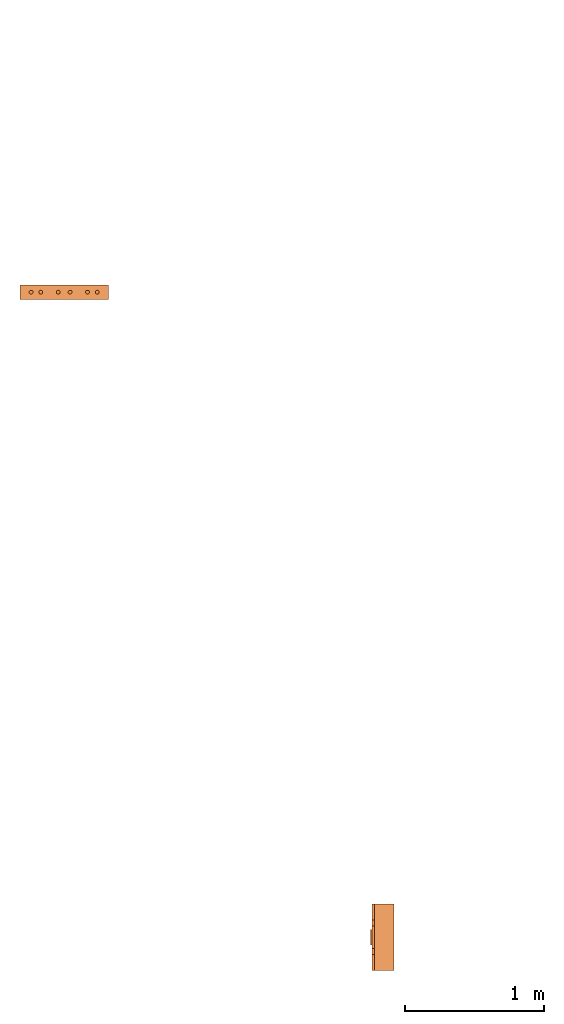
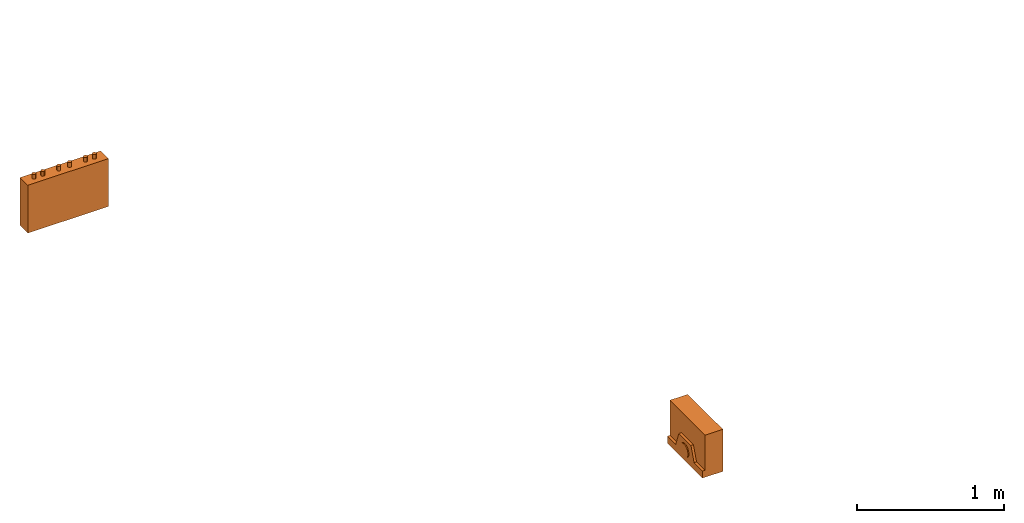
# One storey, part 1 of 4: 2 proxies.
"""IFC2X3 building model written with IfcOpenShell, lengths in millimetres."""

from ifc_helpers import new_model, entity, si_unit, converted_unit, derived_unit, direction, frame, origin, place, context, subcontext, project, spatial, faceted_brep, source, transform, mapped, material, material_list, type_object, type_shapes, element, save


model = new_model("IFC2X3")

# Units and contexts
model_context = context("Model", 3, precision=0.01, world=origin(), true_north=direction((6.12303176911189e-17, 1.0)))
body_context = subcontext(model_context, "Body", "Model", "MODEL_VIEW")
ifc_project = project(units=[si_unit("LENGTHUNIT", "METRE", prefix="MILLI"), si_unit("AREAUNIT", "SQUARE_METRE"), si_unit("VOLUMEUNIT", "CUBIC_METRE"), converted_unit("PLANEANGLEUNIT", "DEGREE", entity("IfcRatioMeasure", 0.0174532925199433), si_unit("PLANEANGLEUNIT", "RADIAN"), dimensions=[0, 0, 0, 0, 0, 0, 0]), si_unit("MASSUNIT", "GRAM", prefix="KILO"), derived_unit("MASSDENSITYUNIT", [(si_unit("MASSUNIT", "GRAM", prefix="KILO"), 1), (si_unit("LENGTHUNIT", "METRE"), -3)]), derived_unit("MOMENTOFINERTIAUNIT", [(si_unit("LENGTHUNIT", "METRE"), 4)]), si_unit("TIMEUNIT", "SECOND"), si_unit("FREQUENCYUNIT", "HERTZ"), si_unit("THERMODYNAMICTEMPERATUREUNIT", "DEGREE_CELSIUS"), derived_unit("THERMALTRANSMITTANCEUNIT", [(si_unit("MASSUNIT", "GRAM", prefix="KILO"), 1), (si_unit("THERMODYNAMICTEMPERATUREUNIT", "KELVIN"), -1), (si_unit("TIMEUNIT", "SECOND"), -3)]), derived_unit("VOLUMETRICFLOWRATEUNIT", [(si_unit("LENGTHUNIT", "METRE"), 3), (si_unit("TIMEUNIT", "SECOND"), -1)]), derived_unit("MASSFLOWRATEUNIT", [(si_unit("MASSUNIT", "GRAM", prefix="KILO"), 1), (si_unit("TIMEUNIT", "SECOND"), -1)]), derived_unit("ROTATIONALFREQUENCYUNIT", [(si_unit("TIMEUNIT", "SECOND"), -1)]), si_unit("ELECTRICCURRENTUNIT", "AMPERE"), si_unit("ELECTRICVOLTAGEUNIT", "VOLT"), si_unit("POWERUNIT", "WATT"), si_unit("FORCEUNIT", "NEWTON", prefix="KILO"), si_unit("ILLUMINANCEUNIT", "LUX"), si_unit("LUMINOUSFLUXUNIT", "LUMEN"), si_unit("LUMINOUSINTENSITYUNIT", "CANDELA"), derived_unit("USERDEFINED", [(si_unit("MASSUNIT", "GRAM", prefix="KILO"), -1), (si_unit("LENGTHUNIT", "METRE"), -2), (si_unit("TIMEUNIT", "SECOND"), 3), (si_unit("LUMINOUSFLUXUNIT", "LUMEN"), 1)]), derived_unit("LINEARVELOCITYUNIT", [(si_unit("LENGTHUNIT", "METRE"), 1), (si_unit("TIMEUNIT", "SECOND"), -1)]), si_unit("PRESSUREUNIT", "PASCAL"), derived_unit("USERDEFINED", [(si_unit("LENGTHUNIT", "METRE"), -2), (si_unit("MASSUNIT", "GRAM", prefix="KILO"), 1), (si_unit("TIMEUNIT", "SECOND"), -2)]), derived_unit("LINEARFORCEUNIT", [(si_unit("MASSUNIT", "GRAM", prefix="KILO"), 1), (si_unit("LENGTHUNIT", "METRE"), 1), (si_unit("TIMEUNIT", "SECOND"), -2), (si_unit("LENGTHUNIT", "METRE"), -1)]), derived_unit("PLANARFORCEUNIT", [(si_unit("MASSUNIT", "GRAM", prefix="KILO"), 1), (si_unit("LENGTHUNIT", "METRE"), 1), (si_unit("TIMEUNIT", "SECOND"), -2), (si_unit("LENGTHUNIT", "METRE"), -2)])], contexts=[model_context])

# Site, building, storey
site_placement = place(None, frame((0.0, 2493.83037508239, 0.0)))
site = spatial("IfcSite", under=ifc_project, at=site_placement, CompositionType="ELEMENT")
building_placement = place(site_placement, origin())
building = spatial("IfcBuilding", under=site, at=building_placement, CompositionType="ELEMENT")
storey_placement = place(building_placement, frame((0.0, 0.0, 15900.0)))
storey = spatial("IfcBuildingStorey", under=building, at=storey_placement, Name="05", CompositionType="ELEMENT", Elevation=15900.0)

# Proxies
ifc_material_1 = material()
ifc_material_2 = material()
ifc_material_list_1 = material_list([ifc_material_1, ifc_material_2])
building_element_proxy_type_1 = type_object("IfcBuildingElementProxyType", PredefinedType="NOTDEFINED", material=ifc_material_1)
shared_shape_1 = source(origin(), body_context, "Body", "Brep", [
    faceted_brep([(168.201612490282, 212.500000000001, 135.54049916809), (168.201612490282, 201.109127034741, 126.799974925206), (168.201612490282, 192.368602791857, 115.409101959946), (168.201612490282, 186.874079554102, 102.144149440585), (168.201612490282, 185.0, 87.9091019599461), (168.201612490282, 186.874079554102, 73.6740544793074), (168.201612490282, 192.368602791856, 60.4091019599461), (168.201612490282, 201.10912703474, 49.0182289946861), (168.201612490282, 212.500000000001, 40.2777047518019), (168.201612490282, 225.764952519362, 34.7831815140474), (168.201612490282, 240.0, 32.9091019599461), (168.201612490282, 254.235047480639, 34.7831815140472), (168.201612490282, 267.5, 40.2777047518019), (168.201612490282, 278.890872965261, 49.0182289946858), (168.201612490282, 287.631397208145, 60.4091019599458), (168.201612490282, 293.125920445899, 73.6740544793071), (168.201612490282, 295.0, 87.9091019599458), (168.201612490282, 293.125920445899, 102.144149440584), (168.201612490282, 287.631397208145, 115.409101959946), (168.201612490282, 278.890872965261, 126.799974925206), (168.201612490282, 267.500000000001, 135.54049916809), (168.201612490282, 254.235047480639, 141.035022405845), (168.201612490282, 240.0, 142.909101959946), (168.201612490282, 225.764952519362, 141.035022405845), (160.0, 225.764952519362, 34.7831815140474), (160.0, 212.500000000001, 40.2777047518019), (160.0, 201.10912703474, 49.0182289946861), (160.0, 192.368602791856, 60.4091019599461), (160.0, 186.874079554102, 73.6740544793074), (160.0, 185.0, 87.9091019599463), (160.0, 186.874079554102, 102.144149440585), (160.0, 192.368602791857, 115.409101959946), (160.0, 201.109127034741, 126.799974925206), (160.0, 212.500000000001, 135.54049916809), (160.0, 225.764952519362, 141.035022405845), (160.0, 240.0, 142.909101959946), (160.0, 254.235047480639, 141.035022405845), (160.0, 267.500000000001, 135.54049916809), (160.0, 278.890872965261, 126.799974925206), (160.0, 287.631397208145, 115.409101959946), (160.0, 293.125920445899, 102.144149440584), (160.0, 295.0, 87.9091019599458), (160.0, 293.125920445899, 73.6740544793071), (160.0, 287.631397208145, 60.4091019599458), (160.0, 278.890872965261, 49.0182289946858), (160.0, 267.5, 40.2777047518019), (160.0, 254.235047480639, 34.7831815140472), (160.0, 240.0, 32.9091019599461)], [[[0, 1, 2, 3, 4, 5, 6, 7, 8, 9, 10, 11, 12, 13, 14, 15, 16, 17, 18, 19, 20, 21, 22, 23]], [[24, 25, 26, 27, 28, 29, 30, 31, 32, 33, 34, 35, 36, 37, 38, 39, 40, 41, 42, 43, 44, 45, 46, 47]], [[40, 17, 16, 41]], [[39, 18, 17, 40]], [[20, 19, 38, 37]], [[39, 38, 19, 18]], [[21, 20, 37, 36]], [[22, 21, 36, 35]], [[34, 23, 22, 35]], [[33, 0, 23, 34]], [[2, 1, 32, 31]], [[33, 32, 1, 0]], [[3, 2, 31, 30]], [[4, 3, 30, 29]], [[28, 5, 4, 29]], [[27, 6, 5, 28]], [[8, 7, 26, 25]], [[27, 26, 7, 6]], [[9, 8, 25, 24]], [[10, 9, 24, 47]], [[46, 11, 10, 47]], [[45, 12, 11, 46]], [[14, 13, 44, 43]], [[45, 44, 13, 12]], [[15, 14, 43, 42]], [[16, 15, 42, 41]]]),
    faceted_brep([(160.0, 0.0, 0.0), (160.0, 480.0, 0.0), (160.0, 480.0, 58.2870579365997), (160.0, 365.0, 58.2870579366005), (160.0, 322.247482084292, 175.748635534839), (160.0, 157.75251791571, 175.748635534839), (160.0, 115.0, 58.2870579366), (160.0, 0.0, 58.2870579365997), (0.0, 480.0, 0.0), (0.0, 0.0, 0.0), (0.0, 0.0, 350.0), (0.0, 480.0, 350.0), (140.211167148102, 480.0, 350.0), (140.211167148102, 480.0, 58.2870579365997), (140.211167148102, 0.0, 350.0), (140.211167148102, 0.0, 58.2870579365997), (140.211167148102, 365.0, 58.2870579366), (140.211167148102, 115.0, 58.2870579366), (140.211167148102, 157.75251791571, 175.748635534839), (140.211167148102, 322.247482084292, 175.748635534839)], [[[0, 1, 2, 3, 4, 5, 6, 7]], [[8, 9, 10, 11]], [[8, 11, 12, 13, 2, 1]], [[11, 10, 14, 12]], [[10, 9, 0, 7, 15, 14]], [[1, 0, 9, 8]], [[16, 13, 12, 14, 15, 17, 18, 19]], [[13, 16, 3, 2]], [[17, 15, 7, 6]], [[18, 17, 6, 5]], [[19, 18, 5, 4]], [[16, 19, 4, 3]]]),
])
type_shapes(building_element_proxy_type_1, [shared_shape_1])
proxy_1_placement = place(storey_placement, frame((21107.6085349596, 1076.9044663698, 1500.0), z_axis=(0.0, 0.0, 1.0), x_axis=(-1.0, 0.0, 0.0)))
element("IfcBuildingElementProxy", 1, at=proxy_1_placement, inside=storey, type_object=building_element_proxy_type_1, material=ifc_material_list_1, context=body_context, shape_type="MappedRepresentation", body=[
    mapped(shared_shape_1, transform((0.0, 0.0, 0.0), scale=1.0)),
])
ifc_material_3 = material()
ifc_material_list_2 = material_list([ifc_material_3, ifc_material_2])
building_element_proxy_type_2 = type_object("IfcBuildingElementProxyType", PredefinedType="NOTDEFINED", material=ifc_material_3)
shared_shape_2 = source(origin(), body_context, "Body", "Brep", [
    faceted_brep([(61.7366777047886, 89.258069163288, 398.0), (63.9615384211591, 86.3585742266764, 398.0), (65.3601443362239, 82.9820408581116, 398.0), (65.837182768177, 79.3585742266763, 398.0), (65.3601443362239, 75.735107595241, 398.0), (63.9615384211591, 72.3585742266763, 398.0), (61.7366777047886, 69.4590792900646, 398.0), (58.8371827681769, 67.2342185736942, 398.0), (55.4606493996122, 65.8356126586294, 398.0), (51.8371827681769, 65.3585742266764, 398.0), (48.2137161367416, 65.8356126586295, 398.0), (44.8371827681769, 67.2342185736943, 398.0), (41.9376878315653, 69.4590792900647, 398.0), (39.7128271151948, 72.3585742266764, 398.0), (38.31422120013, 75.7351075952411, 398.0), (37.837182768177, 79.3585742266764, 398.0), (38.31422120013, 82.9820408581117, 398.0), (39.7128271151949, 86.3585742266764, 398.0), (41.9376878315653, 89.258069163288, 398.0), (44.837182768177, 91.4829298796585, 398.0), (48.2137161367417, 92.8815357947233, 398.0), (51.837182768177, 93.3585742266764, 398.0), (55.4606493996123, 92.8815357947233, 398.0), (58.837182768177, 91.4829298796585, 398.0), (58.8371827681769, 67.2342185736942, 436.716690815491), (61.7366777047886, 69.4590792900646, 436.716690815491), (63.9615384211591, 72.3585742266763, 436.716690815491), (65.3601443362239, 75.735107595241, 436.716690815491), (65.837182768177, 79.3585742266764, 436.716690815491), (65.3601443362239, 82.9820408581116, 436.716690815491), (63.9615384211591, 86.3585742266764, 436.716690815491), (61.7366777047886, 89.258069163288, 436.716690815491), (58.837182768177, 91.4829298796585, 436.716690815491), (55.4606493996123, 92.8815357947233, 436.716690815491), (51.837182768177, 93.3585742266764, 436.716690815491), (48.2137161367417, 92.8815357947233, 436.716690815491), (44.837182768177, 91.4829298796585, 436.716690815491), (41.9376878315653, 89.258069163288, 436.716690815491), (39.7128271151949, 86.3585742266764, 436.716690815491), (38.31422120013, 82.9820408581117, 436.716690815491), (37.837182768177, 79.3585742266764, 436.716690815491), (38.31422120013, 75.7351075952411, 436.716690815491), (39.7128271151948, 72.3585742266764, 436.716690815491), (41.9376878315653, 69.4590792900647, 436.716690815491), (44.8371827681769, 67.2342185736943, 436.716690815491), (48.2137161367416, 65.8356126586295, 436.716690815491), (51.8371827681769, 65.3585742266764, 436.716690815491), (55.4606493996122, 65.8356126586294, 436.716690815491)], [[[0, 1, 2, 3, 4, 5, 6, 7, 8, 9, 10, 11, 12, 13, 14, 15, 16, 17, 18, 19, 20, 21, 22, 23]], [[24, 25, 26, 27, 28, 29, 30, 31, 32, 33, 34, 35, 36, 37, 38, 39, 40, 41, 42, 43, 44, 45, 46, 47]], [[40, 15, 14, 41]], [[13, 42, 41, 14]], [[43, 12, 11, 44]], [[13, 12, 43, 42]], [[44, 11, 10, 45]], [[9, 46, 45, 10]], [[47, 8, 7, 24]], [[6, 25, 24, 7]], [[26, 5, 4, 27]], [[6, 5, 26, 25]], [[27, 4, 3, 28]], [[47, 46, 9, 8]], [[1, 30, 29, 2]], [[0, 31, 30, 1]], [[22, 33, 32, 23]], [[23, 32, 31, 0]], [[21, 34, 33, 22]], [[28, 3, 2, 29]], [[35, 20, 19, 36]], [[18, 37, 36, 19]], [[38, 17, 16, 39]], [[18, 17, 38, 37]], [[39, 16, 15, 40]], [[35, 34, 21, 20]]]),
    faceted_brep([(58.837182768177, 542.517070120343, 436.716690815491), (61.7366777047886, 544.741930836713, 436.716690815491), (63.9615384211591, 547.641425773325, 436.716690815491), (65.360144336224, 551.017959141889, 436.716690815491), (65.837182768177, 554.641425773325, 436.716690815491), (65.360144336224, 558.26489240476, 436.716690815491), (63.9615384211592, 561.641425773325, 436.716690815491), (61.7366777047887, 564.540920709937, 436.716690815491), (58.8371827681771, 566.765781426307, 436.716690815491), (55.4606493996123, 568.164387341372, 436.716690815491), (51.8371827681771, 568.641425773325, 436.716690815491), (48.2137161367418, 568.164387341372, 436.716690815491), (44.8371827681771, 566.765781426307, 436.716690815491), (41.9376878315654, 564.540920709937, 436.716690815491), (39.7128271151949, 561.641425773325, 436.716690815491), (38.3142212001301, 558.26489240476, 436.716690815491), (37.837182768177, 554.641425773325, 436.716690815491), (38.3142212001301, 551.01795914189, 436.716690815491), (39.7128271151949, 547.641425773325, 436.716690815491), (41.9376878315653, 544.741930836713, 436.716690815491), (44.837182768177, 542.517070120343, 436.716690815491), (48.2137161367417, 541.118464205278, 436.716690815491), (51.837182768177, 540.641425773325, 436.716690815491), (55.4606493996123, 541.118464205278, 436.716690815491), (51.8371827681771, 568.641425773325, 398.0), (55.4606493996123, 568.164387341372, 398.0), (58.8371827681771, 566.765781426307, 398.0), (61.7366777047887, 564.540920709937, 398.0), (63.9615384211592, 561.641425773325, 398.0), (65.360144336224, 558.26489240476, 398.0), (65.837182768177, 554.641425773325, 398.0), (65.360144336224, 551.017959141889, 398.0), (63.9615384211591, 547.641425773325, 398.0), (61.7366777047886, 544.741930836713, 398.0), (58.837182768177, 542.517070120343, 398.0), (55.4606493996123, 541.118464205278, 398.0), (51.837182768177, 540.641425773325, 398.0), (48.2137161367417, 541.118464205278, 398.0), (44.837182768177, 542.517070120343, 398.0), (41.9376878315653, 544.741930836713, 398.0), (39.7128271151949, 547.641425773325, 398.0), (38.3142212001301, 551.01795914189, 398.0), (37.837182768177, 554.641425773325, 398.0), (38.3142212001301, 558.26489240476, 398.0), (39.7128271151949, 561.641425773325, 398.0), (41.9376878315654, 564.540920709937, 398.0), (44.8371827681771, 566.765781426307, 398.0), (48.2137161367418, 568.164387341372, 398.0)], [[[0, 1, 2, 3, 4, 5, 6, 7, 8, 9, 10, 11, 12, 13, 14, 15, 16, 17, 18, 19, 20, 21, 22, 23]], [[24, 25, 26, 27, 28, 29, 30, 31, 32, 33, 34, 35, 36, 37, 38, 39, 40, 41, 42, 43, 44, 45, 46, 47]], [[17, 41, 40, 18]], [[39, 19, 18, 40]], [[20, 38, 37, 21]], [[39, 38, 20, 19]], [[21, 37, 36, 22]], [[41, 17, 16, 42]], [[23, 35, 34, 0]], [[33, 1, 0, 34]], [[2, 32, 31, 3]], [[33, 32, 2, 1]], [[3, 31, 30, 4]], [[35, 23, 22, 36]], [[29, 5, 4, 30]], [[28, 6, 5, 29]], [[9, 25, 24, 10]], [[27, 7, 6, 28]], [[26, 8, 7, 27]], [[26, 25, 9, 8]], [[11, 47, 46, 12]], [[45, 13, 12, 46]], [[14, 44, 43, 15]], [[45, 44, 14, 13]], [[15, 43, 42, 16]], [[47, 11, 10, 24]]]),
    faceted_brep([(58.8371827681769, 472.517070120343, 436.716690815491), (61.7366777047886, 474.741930836713, 436.716690815491), (63.961538421159, 477.641425773325, 436.716690815491), (65.3601443362239, 481.017959141889, 436.716690815491), (65.8371827681769, 484.641425773325, 436.716690815491), (65.3601443362239, 488.26489240476, 436.716690815491), (63.9615384211591, 491.641425773325, 436.716690815491), (61.7366777047886, 494.540920709936, 436.716690815491), (58.837182768177, 496.765781426307, 436.716690815491), (55.4606493996123, 498.164387341372, 436.716690815491), (51.837182768177, 498.641425773325, 436.716690815491), (48.2137161367417, 498.164387341372, 436.716690815491), (44.837182768177, 496.765781426307, 436.716690815491), (41.9376878315653, 494.540920709937, 436.716690815491), (39.7128271151948, 491.641425773325, 436.716690815491), (38.31422120013, 488.26489240476, 436.716690815491), (37.837182768177, 484.641425773325, 436.716690815491), (38.31422120013, 481.01795914189, 436.716690815491), (39.7128271151948, 477.641425773325, 436.716690815491), (41.9376878315653, 474.741930836713, 436.716690815491), (44.8371827681769, 472.517070120343, 436.716690815491), (48.2137161367416, 471.118464205278, 436.716690815491), (51.8371827681769, 470.641425773325, 436.716690815491), (55.4606493996122, 471.118464205278, 436.716690815491), (51.837182768177, 498.641425773325, 398.0), (55.4606493996123, 498.164387341372, 398.0), (58.837182768177, 496.765781426307, 398.0), (61.7366777047886, 494.540920709936, 398.0), (63.9615384211591, 491.641425773325, 398.0), (65.3601443362239, 488.26489240476, 398.0), (65.8371827681769, 484.641425773325, 398.0), (65.3601443362239, 481.017959141889, 398.0), (63.961538421159, 477.641425773325, 398.0), (61.7366777047886, 474.741930836713, 398.0), (58.8371827681769, 472.517070120343, 398.0), (55.4606493996122, 471.118464205278, 398.0), (51.8371827681769, 470.641425773325, 398.0), (48.2137161367416, 471.118464205278, 398.0), (44.8371827681769, 472.517070120343, 398.0), (41.9376878315653, 474.741930836713, 398.0), (39.7128271151948, 477.641425773325, 398.0), (38.31422120013, 481.01795914189, 398.0), (37.837182768177, 484.641425773325, 398.0), (38.31422120013, 488.26489240476, 398.0), (39.7128271151948, 491.641425773325, 398.0), (41.9376878315653, 494.540920709937, 398.0), (44.837182768177, 496.765781426307, 398.0), (48.2137161367417, 498.164387341372, 398.0)], [[[0, 1, 2, 3, 4, 5, 6, 7, 8, 9, 10, 11, 12, 13, 14, 15, 16, 17, 18, 19, 20, 21, 22, 23]], [[24, 25, 26, 27, 28, 29, 30, 31, 32, 33, 34, 35, 36, 37, 38, 39, 40, 41, 42, 43, 44, 45, 46, 47]], [[16, 42, 41, 17]], [[40, 18, 17, 41]], [[19, 39, 38, 20]], [[40, 39, 19, 18]], [[20, 38, 37, 21]], [[36, 22, 21, 37]], [[23, 35, 34, 0]], [[33, 1, 0, 34]], [[2, 32, 31, 3]], [[33, 32, 2, 1]], [[3, 31, 30, 4]], [[23, 22, 36, 35]], [[28, 6, 5, 29]], [[27, 7, 6, 28]], [[25, 9, 8, 26]], [[26, 8, 7, 27]], [[24, 10, 9, 25]], [[4, 30, 29, 5]], [[11, 47, 46, 12]], [[45, 13, 12, 46]], [[14, 44, 43, 15]], [[45, 44, 14, 13]], [[15, 43, 42, 16]], [[11, 10, 24, 47]]]),
    faceted_brep([(58.8371827681766, 347.517070120343, 436.716690815491), (61.7366777047883, 349.741930836713, 436.716690815491), (63.9615384211588, 352.641425773325, 436.716690815491), (65.3601443362236, 356.017959141889, 436.716690815491), (65.8371827681767, 359.641425773325, 436.716690815491), (65.3601443362237, 363.26489240476, 436.716690815491), (63.9615384211589, 366.641425773325, 436.716690815491), (61.7366777047884, 369.540920709937, 436.716690815491), (58.8371827681767, 371.765781426307, 436.716690815491), (55.460649399612, 373.164387341372, 436.716690815491), (51.8371827681767, 373.641425773325, 436.716690815491), (48.2137161367414, 373.164387341372, 436.716690815491), (44.8371827681767, 371.765781426307, 436.716690815491), (41.9376878315651, 369.540920709937, 436.716690815491), (39.7128271151946, 366.641425773325, 436.716690815491), (38.3142212001298, 363.26489240476, 436.716690815491), (37.8371827681767, 359.641425773325, 436.716690815491), (38.3142212001298, 356.01795914189, 436.716690815491), (39.7128271151945, 352.641425773325, 436.716690815491), (41.937687831565, 349.741930836713, 436.716690815491), (44.8371827681767, 347.517070120343, 436.716690815491), (48.2137161367414, 346.118464205278, 436.716690815491), (51.8371827681766, 345.641425773325, 436.716690815491), (55.4606493996119, 346.118464205278, 436.716690815491), (51.8371827681767, 373.641425773325, 398.0), (55.460649399612, 373.164387341372, 398.0), (58.8371827681767, 371.765781426307, 398.0), (61.7366777047884, 369.540920709937, 398.0), (63.9615384211589, 366.641425773325, 398.0), (65.3601443362237, 363.26489240476, 398.0), (65.8371827681767, 359.641425773325, 398.0), (65.3601443362236, 356.017959141889, 398.0), (63.9615384211588, 352.641425773325, 398.0), (61.7366777047883, 349.741930836713, 398.0), (58.8371827681766, 347.517070120343, 398.0), (55.4606493996119, 346.118464205278, 398.0), (51.8371827681766, 345.641425773325, 398.0), (48.2137161367414, 346.118464205278, 398.0), (44.8371827681767, 347.517070120343, 398.0), (41.937687831565, 349.741930836713, 398.0), (39.7128271151945, 352.641425773325, 398.0), (38.3142212001298, 356.01795914189, 398.0), (37.8371827681767, 359.641425773325, 398.0), (38.3142212001298, 363.26489240476, 398.0), (39.7128271151946, 366.641425773325, 398.0), (41.9376878315651, 369.540920709937, 398.0), (44.8371827681767, 371.765781426307, 398.0), (48.2137161367414, 373.164387341372, 398.0)], [[[0, 1, 2, 3, 4, 5, 6, 7, 8, 9, 10, 11, 12, 13, 14, 15, 16, 17, 18, 19, 20, 21, 22, 23]], [[24, 25, 26, 27, 28, 29, 30, 31, 32, 33, 34, 35, 36, 37, 38, 39, 40, 41, 42, 43, 44, 45, 46, 47]], [[16, 42, 41, 17]], [[40, 18, 17, 41]], [[19, 39, 38, 20]], [[40, 39, 19, 18]], [[20, 38, 37, 21]], [[36, 22, 21, 37]], [[23, 35, 34, 0]], [[33, 1, 0, 34]], [[2, 32, 31, 3]], [[33, 32, 2, 1]], [[3, 31, 30, 4]], [[23, 22, 36, 35]], [[28, 6, 5, 29]], [[27, 7, 6, 28]], [[25, 9, 8, 26]], [[26, 8, 7, 27]], [[24, 10, 9, 25]], [[4, 30, 29, 5]], [[11, 47, 46, 12]], [[45, 13, 12, 46]], [[14, 44, 43, 15]], [[45, 44, 14, 13]], [[15, 43, 42, 16]], [[11, 10, 24, 47]]]),
    faceted_brep([(58.8371827681766, 262.234218573694, 436.716690815491), (61.7366777047883, 264.459079290065, 436.716690815491), (63.9615384211588, 267.358574226676, 436.716690815491), (65.3601443362236, 270.735107595241, 436.716690815491), (65.8371827681767, 274.358574226676, 436.716690815491), (65.3601443362237, 277.982040858112, 436.716690815491), (63.9615384211588, 281.358574226676, 436.716690815491), (61.7366777047884, 284.258069163288, 436.716690815491), (58.8371827681767, 286.482929879658, 436.716690815491), (55.460649399612, 287.881535794723, 436.716690815491), (51.8371827681767, 288.358574226676, 436.716690815491), (48.2137161367414, 287.881535794723, 436.716690815491), (44.8371827681767, 286.482929879659, 436.716690815491), (41.9376878315651, 284.258069163288, 436.716690815491), (39.7128271151946, 281.358574226676, 436.716690815491), (38.3142212001298, 277.982040858112, 436.716690815491), (37.8371827681767, 274.358574226676, 436.716690815491), (38.3142212001297, 270.735107595241, 436.716690815491), (39.7128271151945, 267.358574226676, 436.716690815491), (41.937687831565, 264.459079290065, 436.716690815491), (44.8371827681767, 262.234218573694, 436.716690815491), (48.2137161367414, 260.835612658629, 436.716690815491), (51.8371827681766, 260.358574226676, 436.716690815491), (55.4606493996119, 260.835612658629, 436.716690815491), (51.8371827681767, 288.358574226676, 398.0), (55.460649399612, 287.881535794723, 398.0), (58.8371827681767, 286.482929879658, 398.0), (61.7366777047884, 284.258069163288, 398.0), (63.9615384211588, 281.358574226676, 398.0), (65.3601443362237, 277.982040858112, 398.0), (65.8371827681767, 274.358574226676, 398.0), (65.3601443362236, 270.735107595241, 398.0), (63.9615384211588, 267.358574226676, 398.0), (61.7366777047883, 264.459079290065, 398.0), (58.8371827681766, 262.234218573694, 398.0), (55.4606493996119, 260.835612658629, 398.0), (51.8371827681766, 260.358574226676, 398.0), (48.2137161367414, 260.835612658629, 398.0), (44.8371827681767, 262.234218573694, 398.0), (41.937687831565, 264.459079290065, 398.0), (39.7128271151945, 267.358574226676, 398.0), (38.3142212001297, 270.735107595241, 398.0), (37.8371827681767, 274.358574226676, 398.0), (38.3142212001298, 277.982040858112, 398.0), (39.7128271151946, 281.358574226676, 398.0), (41.9376878315651, 284.258069163288, 398.0), (44.8371827681767, 286.482929879659, 398.0), (48.2137161367414, 287.881535794723, 398.0)], [[[0, 1, 2, 3, 4, 5, 6, 7, 8, 9, 10, 11, 12, 13, 14, 15, 16, 17, 18, 19, 20, 21, 22, 23]], [[24, 25, 26, 27, 28, 29, 30, 31, 32, 33, 34, 35, 36, 37, 38, 39, 40, 41, 42, 43, 44, 45, 46, 47]], [[16, 42, 41, 17]], [[40, 18, 17, 41]], [[19, 39, 38, 20]], [[40, 39, 19, 18]], [[20, 38, 37, 21]], [[36, 22, 21, 37]], [[23, 35, 34, 0]], [[33, 1, 0, 34]], [[2, 32, 31, 3]], [[33, 32, 2, 1]], [[3, 31, 30, 4]], [[23, 22, 36, 35]], [[4, 30, 29, 5]], [[28, 6, 5, 29]], [[7, 27, 26, 8]], [[28, 27, 7, 6]], [[8, 26, 25, 9]], [[24, 10, 9, 25]], [[11, 47, 46, 12]], [[45, 13, 12, 46]], [[14, 44, 43, 15]], [[45, 44, 14, 13]], [[15, 43, 42, 16]], [[11, 10, 24, 47]]]),
    faceted_brep([(58.8371827681768, 137.234218573694, 436.716690815491), (61.7366777047885, 139.459079290065, 436.716690815491), (63.961538421159, 142.358574226676, 436.716690815491), (65.3601443362238, 145.735107595241, 436.716690815491), (65.8371827681769, 149.358574226676, 436.716690815491), (65.3601443362239, 152.982040858112, 436.716690815491), (63.961538421159, 156.358574226676, 436.716690815491), (61.7366777047886, 159.258069163288, 436.716690815491), (58.8371827681769, 161.482929879659, 436.716690815491), (55.4606493996122, 162.881535794723, 436.716690815491), (51.8371827681769, 163.358574226676, 436.716690815491), (48.2137161367416, 162.881535794723, 436.716690815491), (44.8371827681769, 161.482929879659, 436.716690815491), (41.9376878315653, 159.258069163288, 436.716690815491), (39.7128271151948, 156.358574226676, 436.716690815491), (38.31422120013, 152.982040858112, 436.716690815491), (37.8371827681769, 149.358574226676, 436.716690815491), (38.3142212001299, 145.735107595241, 436.716690815491), (39.7128271151947, 142.358574226676, 436.716690815491), (41.9376878315652, 139.459079290065, 436.716690815491), (44.8371827681769, 137.234218573694, 436.716690815491), (48.2137161367416, 135.83561265863, 436.716690815491), (51.8371827681768, 135.358574226676, 436.716690815491), (55.4606493996121, 135.835612658629, 436.716690815491), (61.7366777047886, 159.258069163288, 398.0), (63.961538421159, 156.358574226676, 398.0), (65.3601443362239, 152.982040858112, 398.0), (65.8371827681769, 149.358574226676, 398.0), (65.3601443362238, 145.735107595241, 398.0), (63.961538421159, 142.358574226676, 398.0), (61.7366777047885, 139.459079290065, 398.0), (58.8371827681768, 137.234218573694, 398.0), (55.4606493996121, 135.835612658629, 398.0), (51.8371827681768, 135.358574226676, 398.0), (48.2137161367416, 135.83561265863, 398.0), (44.8371827681769, 137.234218573694, 398.0), (41.9376878315652, 139.459079290065, 398.0), (39.7128271151947, 142.358574226676, 398.0), (38.3142212001299, 145.735107595241, 398.0), (37.8371827681769, 149.358574226676, 398.0), (38.31422120013, 152.982040858112, 398.0), (39.7128271151948, 156.358574226676, 398.0), (41.9376878315653, 159.258069163288, 398.0), (44.8371827681769, 161.482929879659, 398.0), (48.2137161367416, 162.881535794723, 398.0), (51.8371827681769, 163.358574226676, 398.0), (55.4606493996122, 162.881535794723, 398.0), (58.8371827681769, 161.482929879659, 398.0)], [[[0, 1, 2, 3, 4, 5, 6, 7, 8, 9, 10, 11, 12, 13, 14, 15, 16, 17, 18, 19, 20, 21, 22, 23]], [[24, 25, 26, 27, 28, 29, 30, 31, 32, 33, 34, 35, 36, 37, 38, 39, 40, 41, 42, 43, 44, 45, 46, 47]], [[16, 39, 38, 17]], [[37, 18, 17, 38]], [[19, 36, 35, 20]], [[37, 36, 19, 18]], [[20, 35, 34, 21]], [[33, 22, 21, 34]], [[23, 32, 31, 0]], [[30, 1, 0, 31]], [[2, 29, 28, 3]], [[30, 29, 2, 1]], [[3, 28, 27, 4]], [[23, 22, 33, 32]], [[25, 6, 5, 26]], [[24, 7, 6, 25]], [[46, 9, 8, 47]], [[47, 8, 7, 24]], [[45, 10, 9, 46]], [[4, 27, 26, 5]], [[11, 44, 43, 12]], [[42, 13, 12, 43]], [[14, 41, 40, 15]], [[42, 41, 14, 13]], [[15, 40, 39, 16]], [[11, 10, 45, 44]]]),
    faceted_brep([(106.0, 0.0, 0.0), (106.0, 634.0, 0.0), (106.0, 634.0, 398.0), (106.0, 0.0, 398.0), (0.0, 634.0, 398.0), (0.0, 524.500000000001, 254.822902819641), (0.0, 518.470476127564, 257.320413382257), (0.0, 529.677669529664, 250.849937254693), (0.0, 512.0, 258.17226772503), (0.0, 122.0, 258.17226772503), (0.0, 533.650635094612, 245.672267725029), (0.0, 536.148145657227, 239.642743852593), (0.0, 537.0, 233.17226772503), (0.0, 634.0, 0.0), (0.0, 0.0, 398.0), (0.0, 537.0, 143.17226772503), (0.0, 536.148145657227, 136.701791597467), (0.0, 533.650635094611, 130.67226772503), (0.0, 529.677669529664, 125.494598195366), (0.0, 524.5, 121.521632630419), (0.0, 518.470476127563, 119.024122067803), (0.0, 512.0, 118.17226772503), (0.0, 122.0, 118.172267725031), (0.0, 0.0, 0.0), (0.0, 97.0, 233.17226772503), (0.0, 115.529523872437, 119.024122067805), (0.0, 109.5, 121.521632630421), (0.0, 104.322330470337, 125.494598195368), (0.0, 100.349364905389, 130.672267725032), (0.0, 97.8518543427736, 136.701791597469), (0.0, 97.0, 143.172267725033), (0.0, 97.8518543427739, 239.642743852593), (0.0, 115.529523872438, 257.320413382257), (0.0, 109.500000000001, 254.822902819641), (0.0, 104.322330470337, 250.849937254693), (0.0, 100.34936490539, 245.67226772503), (16.2395209800454, 533.650635094612, 245.672267725029), (16.2395209800454, 536.148145657227, 239.642743852593), (16.2395209800454, 537.0, 233.17226772503), (16.2395209800454, 537.0, 143.17226772503), (16.2395209800454, 536.148145657227, 136.701791597467), (16.2395209800454, 533.650635094611, 130.67226772503), (16.2395209800454, 529.677669529664, 125.494598195366), (16.2395209800454, 524.5, 121.521632630419), (16.2395209800454, 518.470476127563, 119.024122067803), (16.2395209800454, 512.0, 118.17226772503), (16.2395209800454, 122.0, 118.172267725032), (16.2395209800454, 115.529523872437, 119.024122067805), (16.2395209800454, 109.5, 121.521632630421), (16.2395209800454, 104.322330470337, 125.494598195368), (16.2395209800454, 100.349364905389, 130.672267725032), (16.2395209800454, 97.8518543427736, 136.701791597469), (16.2395209800454, 97.0, 143.172267725032), (16.2395209800454, 97.0, 233.17226772503), (16.2395209800454, 97.8518543427739, 239.642743852593), (16.2395209800454, 100.34936490539, 245.67226772503), (16.2395209800454, 104.322330470337, 250.849937254694), (16.2395209800454, 109.500000000001, 254.822902819641), (16.2395209800454, 115.529523872438, 257.320413382257), (16.2395209800454, 122.0, 258.17226772503), (16.2395209800454, 512.0, 258.17226772503), (16.2395209800454, 518.470476127564, 257.320413382257), (16.2395209800454, 524.500000000001, 254.822902819641), (16.2395209800454, 529.677669529664, 250.849937254693)], [[[0, 1, 2, 3]], [[4, 5, 6]], [[5, 4, 7]], [[6, 8, 4]], [[4, 8, 9]], [[10, 7, 4]], [[11, 10, 4]], [[12, 11, 4]], [[4, 13, 12]], [[9, 14, 4]], [[15, 12, 13]], [[16, 15, 13]], [[16, 13, 17]], [[18, 17, 13]], [[13, 19, 18]], [[19, 13, 20]], [[21, 20, 13]], [[13, 22, 21]], [[22, 13, 23]], [[14, 24, 23]], [[25, 22, 23]], [[23, 26, 25]], [[26, 23, 27]], [[28, 27, 23]], [[28, 23, 29]], [[30, 29, 23]], [[30, 23, 24]], [[31, 24, 14]], [[9, 32, 14]], [[33, 14, 32]], [[14, 33, 34]], [[34, 35, 14]], [[35, 31, 14]], [[2, 1, 13, 4]], [[3, 2, 4, 14]], [[0, 3, 14, 23]], [[1, 0, 23, 13]], [[36, 37, 38, 39, 40, 41, 42, 43, 44, 45, 46, 47, 48, 49, 50, 51, 52, 53, 54, 55, 56, 57, 58, 59, 60, 61, 62, 63]], [[9, 8, 60, 59]], [[32, 9, 59, 58]], [[33, 32, 58, 57]], [[33, 57, 56, 34]], [[35, 34, 56, 55]], [[31, 35, 55, 54]], [[31, 54, 53, 24]], [[24, 53, 52, 30]], [[29, 30, 52, 51]], [[28, 29, 51, 50]], [[28, 50, 49, 27]], [[26, 27, 49, 48]], [[25, 26, 48, 47]], [[25, 47, 46, 22]], [[22, 46, 45, 21]], [[20, 21, 45, 44]], [[19, 20, 44, 43]], [[19, 43, 42, 18]], [[17, 18, 42, 41]], [[16, 17, 41, 40]], [[16, 40, 39, 15]], [[15, 39, 38, 12]], [[11, 12, 38, 37]], [[10, 11, 37, 36]], [[10, 36, 63, 7]], [[5, 7, 63, 62]], [[6, 5, 62, 61]], [[6, 61, 60, 8]]]),
])
type_shapes(building_element_proxy_type_2, [shared_shape_2])
proxy_2_placement = place(storey_placement, frame((18421.3718382366, 5521.31843157248, 1500.0), z_axis=(0.0, 0.0, 1.0), x_axis=(0.0, -1.0, 0.0)))
element("IfcBuildingElementProxy", 2, at=proxy_2_placement, inside=storey, type_object=building_element_proxy_type_2, material=ifc_material_list_2, context=body_context, shape_type="MappedRepresentation", body=[
    mapped(shared_shape_2, transform((0.0, 0.0, 0.0), scale=1.0)),
])

save(model, "model.ifc")
